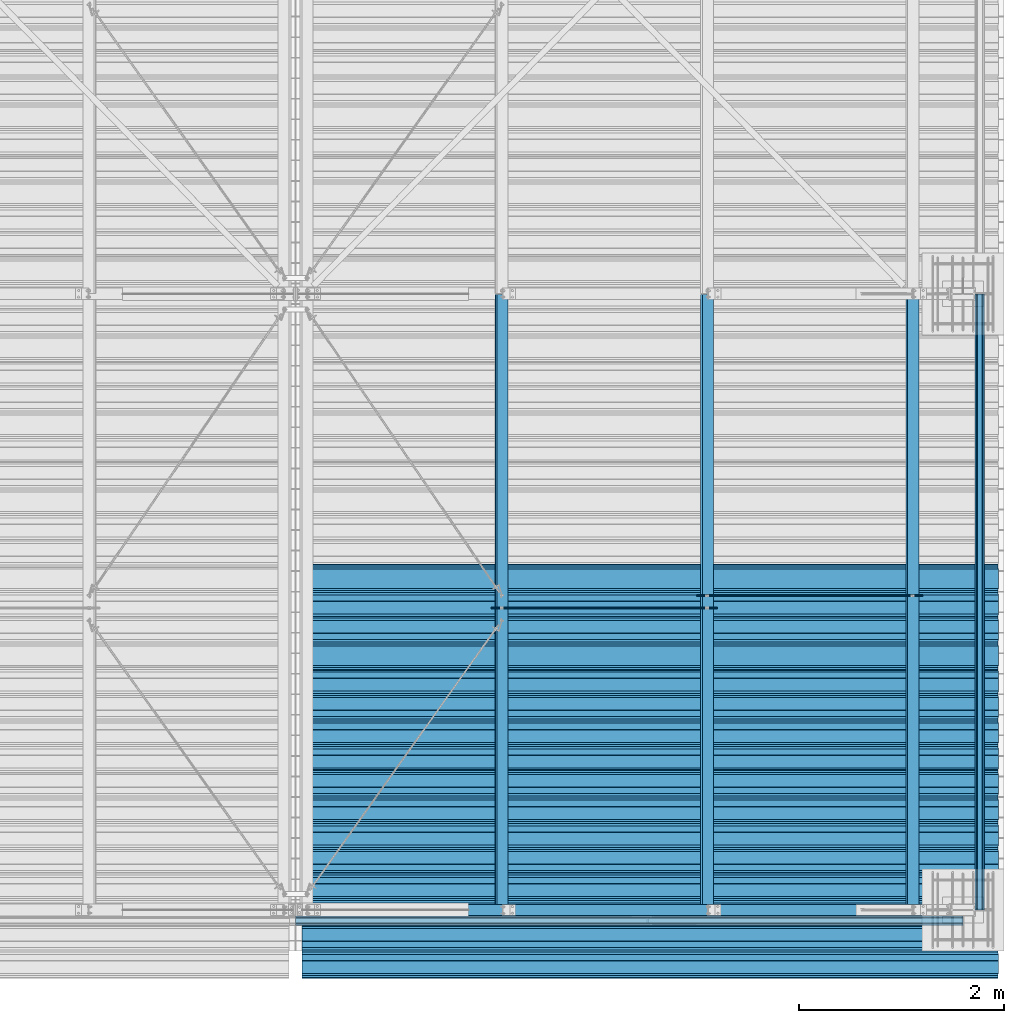
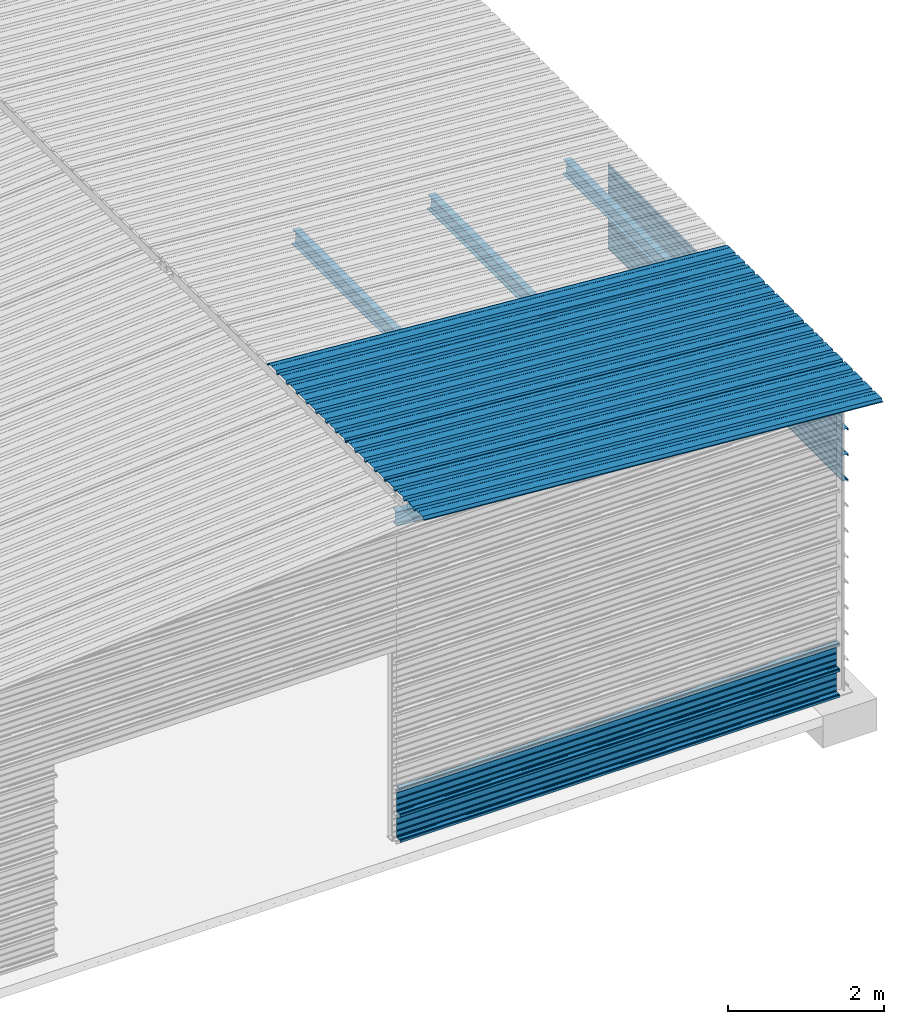
# One storey, part 8 of 70: 16 beams, 16 elements without a shape of their own.
"""IFC2X3 building model written with IfcOpenShell, lengths in millimetres."""

from ifc_helpers import new_model, si_unit, frame, origin_with_axes, origin_2d_with_axis, place, context, subcontext, project, spatial, polyline, circle, i_section, outline, extrude, clip, halfspace, material, type_object, element, aggregate, save


model = new_model("IFC2X3")

# Units and contexts
model_context = context("Model", 3, precision=1e-05, world=origin_with_axes())
body_context = subcontext(model_context, "Body", "Model", "MODEL_VIEW")
ifc_project = project(units=[si_unit("LENGTHUNIT", "METRE", prefix="MILLI"), si_unit("AREAUNIT", "SQUARE_METRE"), si_unit("VOLUMEUNIT", "CUBIC_METRE"), si_unit("MASSUNIT", "GRAM", prefix="KILO"), si_unit("TIMEUNIT", "SECOND"), si_unit("PLANEANGLEUNIT", "RADIAN"), si_unit("SOLIDANGLEUNIT", "STERADIAN"), si_unit("THERMODYNAMICTEMPERATUREUNIT", "DEGREE_CELSIUS"), si_unit("LUMINOUSINTENSITYUNIT", "LUMEN")], contexts=[model_context])

# Site, building, storey
site_placement = place(None, origin_with_axes())
site = spatial("IfcSite", under=ifc_project, at=site_placement, CompositionType="ELEMENT")
building_placement = place(site_placement, origin_with_axes())
building = spatial("IfcBuilding", under=site, at=building_placement, Name="Undefined", CompositionType="ELEMENT")
storey_placement = place(building_placement, origin_with_axes())
storey = spatial("IfcBuildingStorey", under=building, at=storey_placement, Name="Undefined", CompositionType="ELEMENT", Elevation=0.0)

# Assembly, beam
assembly_1_placement = place(storey_placement, origin_with_axes())
assembly_1 = element("IfcElementAssembly", 1, at=assembly_1_placement, inside=storey, Name="Steel Assembly", AssemblyPlace="NOTDEFINED", PredefinedType="RIGID_FRAME")
ifc_material = material(Name="STEEL/S235JR")
beam_type_1 = type_object("IfcBeamType", Name="4.40", PredefinedType="NOTDEFINED")
beam_1_placement = place(assembly_1_placement, frame((6563.60751131961, -149.999999999847, 5336.31760454349), z_axis=(-0.0766964990376782, 0.0, -0.997054485489817), x_axis=(0.997054485489817, 0.0, -0.0766964990376783)))
beam_1 = element("IfcBeam", 2, at=beam_1_placement, type_object=beam_type_1, material=ifc_material, ObjectType="4.40", context=body_context, shape_type="SweptSolid", body=[
    extrude(outline(polyline([(509.415161132813, 19.5000000011705), (490.584838867188, 19.5000000011705), (468.084838867188, -20.4999999988113), (406.585784912109, -20.4999999988113), (404.585784912109, -18.4999999988122), (345.414215087891, -18.4999999988122), (343.414215087891, -20.4999999988113), (281.915161132813, -20.4999999988113), (259.415161132813, 19.5000000011705), (240.584854125977, 19.5000000011705), (218.084854125977, -20.4999999988113), (156.585784912109, -20.4999999988113), (154.585784912109, -18.4999999988122), (95.4142150878906, -18.4999999988122), (93.4142150878906, -20.4999999988113), (31.9151515960693, -20.4999999988113), (9.41515254974365, 19.5000000011705), (-9.41515254974365, 19.5000000011705), (-31.9151515960693, -20.4999999988113), (-93.4142150878906, -20.4999999988113), (-95.4142150878906, -18.4999999988122), (-154.585784912109, -18.4999999988122), (-156.585784912109, -20.4999999988113), (-218.084854125977, -20.4999999988113), (-240.584854125977, 19.5000000011705), (-259.415161132813, 19.5000000011705), (-281.915161132813, -20.4999999988113), (-343.414215087891, -20.4999999988113), (-345.414215087891, -18.4999999988122), (-404.585784912109, -18.4999999988122), (-406.585784912109, -20.4999999988113), (-468.084838867188, -20.4999999988113), (-490.584838867188, 19.5000000011705), (-509.415161132813, 19.5000000011705), (-516.482360839844, 6.9361057293263), (-517.353942871094, 7.42636680720625), (-510.0, 20.5000000011705), (-490.0, 20.5000000011705), (-467.5, -19.4999999988122), (-407.0, -19.4999999988122), (-405.0, -17.4999999988131), (-345.0, -17.4999999988131), (-343.0, -19.4999999988122), (-282.5, -19.4999999988122), (-260.0, 20.5000000011705), (-240.0, 20.5000000011705), (-217.5, -19.4999999988122), (-157.0, -19.4999999988122), (-155.0, -17.4999999988131), (-95.0, -17.4999999988131), (-93.0, -19.4999999988122), (-32.5, -19.4999999988122), (-10.0, 20.5000000011705), (10.0, 20.5000000011705), (32.5, -19.4999999988122), (93.0, -19.4999999988122), (95.0, -17.4999999988131), (155.0, -17.4999999988131), (157.0, -19.4999999988122), (217.5, -19.4999999988122), (240.0, 20.5000000011705), (260.0, 20.5000000011705), (282.5, -19.4999999988122), (343.0, -19.4999999988122), (345.0, -17.4999999988131), (405.0, -17.4999999988131), (407.0, -19.4999999988122), (467.5, -19.4999999988122), (490.0, 20.5000000011705), (510.0, 20.5000000011705), (517.353942871094, 7.42636680720625), (516.482360839844, 6.9361057293263), (509.415161132813, 19.5000000011705)])), frame((6799.99999999733, 2.8421709430404e-14, 0.0), z_axis=(-1.0, 0.0, 0.0), x_axis=(0.0, -1.0, 0.0)), (0.0, 0.0, 1.0), 6800.0),
])
aggregate(assembly_1, [beam_1])

assembly_2_placement = place(storey_placement, origin_with_axes())
assembly_2 = element("IfcElementAssembly", 3, at=assembly_2_placement, inside=storey, Name="Steel Assembly", AssemblyPlace="NOTDEFINED", PredefinedType="RIGID_FRAME")
beam_2_placement = place(assembly_2_placement, frame((6563.60751131961, 850.000000000153, 5336.31760454352), z_axis=(-0.0766964990376782, 0.0, -0.997054485489817), x_axis=(0.997054485489817, 0.0, -0.0766964990376783)))
beam_2 = element("IfcBeam", 4, at=beam_2_placement, type_object=beam_type_1, material=ifc_material, ObjectType="4.40", context=body_context, shape_type="SweptSolid", body=[
    extrude(outline(polyline([(509.415161132813, 19.5000000011705), (490.584838867188, 19.5000000011705), (468.084838867188, -20.4999999988113), (406.585784912109, -20.4999999988113), (404.585784912109, -18.4999999988122), (345.414215087891, -18.4999999988122), (343.414215087891, -20.4999999988113), (281.915161132813, -20.4999999988113), (259.415161132813, 19.5000000011705), (240.584854125977, 19.5000000011705), (218.084854125977, -20.4999999988113), (156.585784912109, -20.4999999988113), (154.585784912109, -18.4999999988122), (95.4142150878906, -18.4999999988122), (93.4142150878906, -20.4999999988113), (31.9151515960693, -20.4999999988113), (9.41515254974365, 19.5000000011705), (-9.41515254974365, 19.5000000011705), (-31.9151515960693, -20.4999999988113), (-93.4142150878906, -20.4999999988113), (-95.4142150878906, -18.4999999988122), (-154.585784912109, -18.4999999988122), (-156.585784912109, -20.4999999988113), (-218.084854125977, -20.4999999988113), (-240.584854125977, 19.5000000011705), (-259.415161132813, 19.5000000011705), (-281.915161132813, -20.4999999988113), (-343.414215087891, -20.4999999988113), (-345.414215087891, -18.4999999988122), (-404.585784912109, -18.4999999988122), (-406.585784912109, -20.4999999988113), (-468.084838867188, -20.4999999988113), (-490.584838867188, 19.5000000011705), (-509.415161132813, 19.5000000011705), (-516.482360839844, 6.9361057293263), (-517.353942871094, 7.42636680720625), (-510.0, 20.5000000011705), (-490.0, 20.5000000011705), (-467.5, -19.4999999988122), (-407.0, -19.4999999988122), (-405.0, -17.4999999988131), (-345.0, -17.4999999988131), (-343.0, -19.4999999988122), (-282.5, -19.4999999988122), (-260.0, 20.5000000011705), (-240.0, 20.5000000011705), (-217.5, -19.4999999988122), (-157.0, -19.4999999988122), (-155.0, -17.4999999988131), (-95.0, -17.4999999988131), (-93.0, -19.4999999988122), (-32.5, -19.4999999988122), (-10.0, 20.5000000011705), (10.0, 20.5000000011705), (32.5, -19.4999999988122), (93.0, -19.4999999988122), (95.0, -17.4999999988131), (155.0, -17.4999999988131), (157.0, -19.4999999988122), (217.5, -19.4999999988122), (240.0, 20.5000000011705), (260.0, 20.5000000011705), (282.5, -19.4999999988122), (343.0, -19.4999999988122), (345.0, -17.4999999988131), (405.0, -17.4999999988131), (407.0, -19.4999999988122), (467.5, -19.4999999988122), (490.0, 20.5000000011705), (510.0, 20.5000000011705), (517.353942871094, 7.42636680720625), (516.482360839844, 6.9361057293263), (509.415161132813, 19.5000000011705)])), frame((6799.99999999733, 2.8421709430404e-14, 0.0), z_axis=(-1.0, 0.0, 0.0), x_axis=(0.0, -1.0, 0.0)), (0.0, 0.0, 1.0), 6800.0),
])
aggregate(assembly_2, [beam_2])

assembly_3_placement = place(storey_placement, origin_with_axes())
assembly_3 = element("IfcElementAssembly", 5, at=assembly_3_placement, inside=storey, Name="Steel Assembly", AssemblyPlace="NOTDEFINED", PredefinedType="RIGID_FRAME")
beam_3_placement = place(assembly_3_placement, frame((6563.60751131961, 1850.00000000015, 5336.31760454355), z_axis=(-0.0766964990376782, 0.0, -0.997054485489817), x_axis=(0.997054485489817, 0.0, -0.0766964990376783)))
beam_3 = element("IfcBeam", 6, at=beam_3_placement, type_object=beam_type_1, material=ifc_material, ObjectType="4.40", context=body_context, shape_type="SweptSolid", body=[
    extrude(outline(polyline([(509.415161132813, 19.5000000011705), (490.584838867188, 19.5000000011705), (468.084838867188, -20.4999999988113), (406.585784912109, -20.4999999988113), (404.585784912109, -18.4999999988122), (345.414215087891, -18.4999999988122), (343.414215087891, -20.4999999988113), (281.915161132813, -20.4999999988113), (259.415161132813, 19.5000000011705), (240.584854125977, 19.5000000011705), (218.084854125977, -20.4999999988113), (156.585784912109, -20.4999999988113), (154.585784912109, -18.4999999988122), (95.4142150878906, -18.4999999988122), (93.4142150878906, -20.4999999988113), (31.9151515960693, -20.4999999988113), (9.41515254974365, 19.5000000011705), (-9.41515254974365, 19.5000000011705), (-31.9151515960693, -20.4999999988113), (-93.4142150878906, -20.4999999988113), (-95.4142150878906, -18.4999999988122), (-154.585784912109, -18.4999999988122), (-156.585784912109, -20.4999999988113), (-218.084854125977, -20.4999999988113), (-240.584854125977, 19.5000000011705), (-259.415161132813, 19.5000000011705), (-281.915161132813, -20.4999999988113), (-343.414215087891, -20.4999999988113), (-345.414215087891, -18.4999999988122), (-404.585784912109, -18.4999999988122), (-406.585784912109, -20.4999999988113), (-468.084838867188, -20.4999999988113), (-490.584838867188, 19.5000000011705), (-509.415161132813, 19.5000000011705), (-516.482360839844, 6.9361057293263), (-517.353942871094, 7.42636680720625), (-510.0, 20.5000000011705), (-490.0, 20.5000000011705), (-467.5, -19.4999999988122), (-407.0, -19.4999999988122), (-405.0, -17.4999999988131), (-345.0, -17.4999999988131), (-343.0, -19.4999999988122), (-282.5, -19.4999999988122), (-260.0, 20.5000000011705), (-240.0, 20.5000000011705), (-217.5, -19.4999999988122), (-157.0, -19.4999999988122), (-155.0, -17.4999999988131), (-95.0, -17.4999999988131), (-93.0, -19.4999999988122), (-32.5, -19.4999999988122), (-10.0, 20.5000000011705), (10.0, 20.5000000011705), (32.5, -19.4999999988122), (93.0, -19.4999999988122), (95.0, -17.4999999988131), (155.0, -17.4999999988131), (157.0, -19.4999999988122), (217.5, -19.4999999988122), (240.0, 20.5000000011705), (260.0, 20.5000000011705), (282.5, -19.4999999988122), (343.0, -19.4999999988122), (345.0, -17.4999999988131), (405.0, -17.4999999988131), (407.0, -19.4999999988122), (467.5, -19.4999999988122), (490.0, 20.5000000011705), (510.0, 20.5000000011705), (517.353942871094, 7.42636680720625), (516.482360839844, 6.9361057293263), (509.415161132813, 19.5000000011705)])), frame((6799.99999999733, 2.8421709430404e-14, 0.0), z_axis=(-1.0, 0.0, 0.0), x_axis=(0.0, -1.0, 0.0)), (0.0, 0.0, 1.0), 6800.0),
])
aggregate(assembly_3, [beam_3])

assembly_4_placement = place(storey_placement, origin_with_axes())
assembly_4 = element("IfcElementAssembly", 7, at=assembly_4_placement, inside=storey, Name="Steel Assembly", AssemblyPlace="NOTDEFINED", PredefinedType="RIGID_FRAME")
beam_4_placement = place(assembly_4_placement, frame((6563.60751131961, 2850.00000000015, 5336.31760454358), z_axis=(-0.0766964990376782, 0.0, -0.997054485489817), x_axis=(0.997054485489817, 0.0, -0.0766964990376783)))
beam_4 = element("IfcBeam", 8, at=beam_4_placement, type_object=beam_type_1, material=ifc_material, ObjectType="4.40", context=body_context, shape_type="SweptSolid", body=[
    extrude(outline(polyline([(509.415161132813, 19.5000000011705), (490.584838867188, 19.5000000011705), (468.084838867188, -20.4999999988113), (406.585784912109, -20.4999999988113), (404.585784912109, -18.4999999988122), (345.414215087891, -18.4999999988122), (343.414215087891, -20.4999999988113), (281.915161132813, -20.4999999988113), (259.415161132813, 19.5000000011705), (240.584854125977, 19.5000000011705), (218.084854125977, -20.4999999988113), (156.585784912109, -20.4999999988113), (154.585784912109, -18.4999999988122), (95.4142150878906, -18.4999999988122), (93.4142150878906, -20.4999999988113), (31.9151515960693, -20.4999999988113), (9.41515254974365, 19.5000000011705), (-9.41515254974365, 19.5000000011705), (-31.9151515960693, -20.4999999988113), (-93.4142150878906, -20.4999999988113), (-95.4142150878906, -18.4999999988122), (-154.585784912109, -18.4999999988122), (-156.585784912109, -20.4999999988113), (-218.084854125977, -20.4999999988113), (-240.584854125977, 19.5000000011705), (-259.415161132813, 19.5000000011705), (-281.915161132813, -20.4999999988113), (-343.414215087891, -20.4999999988113), (-345.414215087891, -18.4999999988122), (-404.585784912109, -18.4999999988122), (-406.585784912109, -20.4999999988113), (-468.084838867188, -20.4999999988113), (-490.584838867188, 19.5000000011705), (-509.415161132813, 19.5000000011705), (-516.482360839844, 6.9361057293263), (-517.353942871094, 7.42636680720625), (-510.0, 20.5000000011705), (-490.0, 20.5000000011705), (-467.5, -19.4999999988122), (-407.0, -19.4999999988122), (-405.0, -17.4999999988131), (-345.0, -17.4999999988131), (-343.0, -19.4999999988122), (-282.5, -19.4999999988122), (-260.0, 20.5000000011705), (-240.0, 20.5000000011705), (-217.5, -19.4999999988122), (-157.0, -19.4999999988122), (-155.0, -17.4999999988131), (-95.0, -17.4999999988131), (-93.0, -19.4999999988122), (-32.5, -19.4999999988122), (-10.0, 20.5000000011705), (10.0, 20.5000000011705), (32.5, -19.4999999988122), (93.0, -19.4999999988122), (95.0, -17.4999999988131), (155.0, -17.4999999988131), (157.0, -19.4999999988122), (217.5, -19.4999999988122), (240.0, 20.5000000011705), (260.0, 20.5000000011705), (282.5, -19.4999999988122), (343.0, -19.4999999988122), (345.0, -17.4999999988131), (405.0, -17.4999999988131), (407.0, -19.4999999988122), (467.5, -19.4999999988122), (490.0, 20.5000000011705), (510.0, 20.5000000011705), (517.353942871094, 7.42636680720625), (516.482360839844, 6.9361057293263), (509.415161132813, 19.5000000011705)])), frame((6799.99999999733, 2.8421709430404e-14, 0.0), z_axis=(-1.0, 0.0, 0.0), x_axis=(0.0, -1.0, 0.0)), (0.0, 0.0, 1.0), 6800.0),
])
aggregate(assembly_4, [beam_4])

assembly_5_placement = place(storey_placement, origin_with_axes())
assembly_5 = element("IfcElementAssembly", 9, at=assembly_5_placement, inside=storey, Name="Steel Assembly", AssemblyPlace="NOTDEFINED", PredefinedType="RIGID_FRAME")
beam_type_2 = type_object("IfcBeamType", Name="400", PredefinedType="NOTDEFINED")
beam_5_placement = place(assembly_5_placement, frame((13000.0, -105.5, 618.25), z_axis=(0.0, -1.0, 0.0), x_axis=(-1.0, 0.0, 0.0)))
beam_5 = element("IfcBeam", 10, at=beam_5_placement, type_object=beam_type_2, material=ifc_material, ObjectType="400", context=body_context, shape_type="SweptSolid", body=[
    extrude(outline(polyline([(218.25, -24.994083404541), (214.25, -31.8999996185303), (214.25, -45.5), (199.75, -45.5), (194.25, -42.5), (188.75, -45.5), (124.25, -45.5), (114.25, -41.5), (104.25, -45.5), (24.25, -45.5), (14.25, -41.5), (4.25, -45.5), (-75.75, -45.5), (-85.75, -41.5), (-95.75, -45.5), (-160.25, -45.5), (-165.75, -42.5), (-171.25, -45.5), (-185.75, -45.5), (-185.75, -30.711540222168), (-181.75, -23.8111782073975), (-181.75, 23.311637878418), (-185.75, 30.2119998931885), (-185.75, 44.5), (-217.25, 44.5), (-217.25, 34.7999992370605), (-218.25, 34.7999992370605), (-218.25, 45.5), (-184.75, 45.5), (-184.75, 30.480884552002), (-180.75, 23.5805225372314), (-180.75, -24.0800628662109), (-184.75, -30.9804248809814), (-184.75, -44.5), (-171.504989624023, -44.5), (-165.75, -41.360912322998), (-159.995010375977, -44.5), (-95.9425811767578, -44.5), (-85.75, -40.422966003418), (-75.5574188232422, -44.5), (4.05741739273071, -44.5), (14.25, -40.422966003418), (24.4425830841064, -44.5), (104.057418823242, -44.5), (114.25, -40.422966003418), (124.442581176758, -44.5), (188.495010375977, -44.5), (194.25, -41.360912322998), (200.004989624023, -44.5), (213.25, -44.5), (213.25, -31.6313018798828), (217.25, -24.7253856658936), (217.25, 21.7253856658936), (213.25, 28.6313018798828), (213.25, 42.0), (187.25, 42.0), (187.25, 32.5499992370605), (186.25, 32.5499992370605), (186.25, 43.0), (214.25, 43.0), (214.25, 28.8999996185303), (218.25, 21.994083404541), (218.25, -24.994083404541)])), frame((6500.0, 0.0, 0.0), z_axis=(-1.0, 0.0, 0.0), x_axis=(0.0, -1.0, 0.0)), (0.0, 0.0, 1.0), 6500.0),
])
aggregate(assembly_5, [beam_5])

assembly_6_placement = place(storey_placement, origin_with_axes())
assembly_6 = element("IfcElementAssembly", 11, at=assembly_6_placement, inside=storey, Name="Steel Assembly", AssemblyPlace="NOTDEFINED", PredefinedType="RIGID_FRAME")
beam_6_placement = place(assembly_6_placement, frame((13000.0, -105.5, 218.25), z_axis=(0.0, -1.0, 0.0), x_axis=(-1.0, 0.0, 0.0)))
beam_6 = element("IfcBeam", 12, at=beam_6_placement, type_object=beam_type_2, material=ifc_material, ObjectType="400", context=body_context, shape_type="SweptSolid", body=[
    extrude(outline(polyline([(218.25, -24.994083404541), (214.25, -31.8999996185303), (214.25, -45.5), (199.75, -45.5), (194.25, -42.5), (188.75, -45.5), (124.25, -45.5), (114.25, -41.5), (104.25, -45.5), (24.25, -45.5), (14.25, -41.5), (4.25, -45.5), (-75.75, -45.5), (-85.75, -41.5), (-95.75, -45.5), (-160.25, -45.5), (-165.75, -42.5), (-171.25, -45.5), (-185.75, -45.5), (-185.75, -30.711540222168), (-181.75, -23.8111782073975), (-181.75, 23.311637878418), (-185.75, 30.2119998931885), (-185.75, 44.5), (-217.25, 44.5), (-217.25, 34.7999992370605), (-218.25, 34.7999992370605), (-218.25, 45.5), (-184.75, 45.5), (-184.75, 30.480884552002), (-180.75, 23.5805225372314), (-180.75, -24.0800628662109), (-184.75, -30.9804248809814), (-184.75, -44.5), (-171.504989624023, -44.5), (-165.75, -41.360912322998), (-159.995010375977, -44.5), (-95.9425811767578, -44.5), (-85.75, -40.422966003418), (-75.5574188232422, -44.5), (4.05741739273071, -44.5), (14.25, -40.422966003418), (24.4425830841064, -44.5), (104.057418823242, -44.5), (114.25, -40.422966003418), (124.442581176758, -44.5), (188.495010375977, -44.5), (194.25, -41.360912322998), (200.004989624023, -44.5), (213.25, -44.5), (213.25, -31.6313018798828), (217.25, -24.7253856658936), (217.25, 21.7253856658936), (213.25, 28.6313018798828), (213.25, 42.0), (187.25, 42.0), (187.25, 32.5499992370605), (186.25, 32.5499992370605), (186.25, 43.0), (214.25, 43.0), (214.25, 28.8999996185303), (218.25, 21.994083404541), (218.25, -24.994083404541)])), frame((6500.0, 0.0, 0.0), z_axis=(-1.0, 0.0, 0.0), x_axis=(0.0, -1.0, 0.0)), (0.0, 0.0, 1.0), 6500.0),
])
aggregate(assembly_6, [beam_6])

assembly_7_placement = place(storey_placement, origin_with_axes())
assembly_7 = element("IfcElementAssembly", 13, at=assembly_7_placement, inside=storey, Name="Steel Assembly", AssemblyPlace="NOTDEFINED", PredefinedType="RIGID_FRAME")
beam_7_placement = place(assembly_7_placement, frame((13165.4999999983, 6000.0, 4618.17396601053), z_axis=(1.0, 0.0, 0.0), x_axis=(0.0, -1.0, 0.0)))
beam_7 = element("IfcBeam", 14, at=beam_7_placement, type_object=beam_type_2, material=ifc_material, ObjectType="400", context=body_context, shape_type="Clipping", body=[
    clip(extrude(outline(polyline([(218.25, -24.994083404541), (214.25, -31.8999996185303), (214.25, -45.5), (199.75, -45.5), (194.25, -42.5), (188.75, -45.5), (124.25, -45.5), (114.25, -41.5), (104.25, -45.5), (24.25, -45.5), (14.25, -41.5), (4.25, -45.5), (-75.75, -45.5), (-85.75, -41.5), (-95.75, -45.5), (-160.25, -45.5), (-165.75, -42.5), (-171.25, -45.5), (-185.75, -45.5), (-185.75, -30.711540222168), (-181.75, -23.8111782073975), (-181.75, 23.311637878418), (-185.75, 30.2119998931885), (-185.75, 44.5), (-217.25, 44.5), (-217.25, 34.7999992370605), (-218.25, 34.7999992370605), (-218.25, 45.5), (-184.75, 45.5), (-184.75, 30.480884552002), (-180.75, 23.5805225372314), (-180.75, -24.0800628662109), (-184.75, -30.9804248809814), (-184.75, -44.5), (-171.504989624023, -44.5), (-165.75, -41.360912322998), (-159.995010375977, -44.5), (-95.9425811767578, -44.5), (-85.75, -40.422966003418), (-75.5574188232422, -44.5), (4.05741739273071, -44.5), (14.25, -40.422966003418), (24.4425830841064, -44.5), (104.057418823242, -44.5), (114.25, -40.422966003418), (124.442581176758, -44.5), (188.495010375977, -44.5), (194.25, -41.360912322998), (200.004989624023, -44.5), (213.25, -44.5), (213.25, -31.6313018798828), (217.25, -24.7253856658936), (217.25, 21.7253856658936), (213.25, 28.6313018798828), (213.25, 42.0), (187.25, 42.0), (187.25, 32.5499992370605), (186.25, 32.5499992370605), (186.25, 43.0), (214.25, 43.0), (214.25, 28.8999996185303), (218.25, 21.994083404541), (218.25, -24.994083404541)])), frame((6000.0, 0.0, 0.0), z_axis=(-1.0, 0.0, 0.0), x_axis=(0.0, -1.0, 0.0)), (0.0, 0.0, 1.0), 6000.0), halfspace(frame((6000.0, 36.6804312648892, -44.9999999999927), z_axis=(0.0, -1.0, 0.0), x_axis=(-1.0, 0.0, 0.0)), False)),
])
aggregate(assembly_7, [beam_7])

assembly_8_placement = place(storey_placement, origin_with_axes())
assembly_8 = element("IfcElementAssembly", 15, at=assembly_8_placement, inside=storey, Name="Steel Assembly", AssemblyPlace="NOTDEFINED", PredefinedType="RIGID_FRAME")
beam_8_placement = place(assembly_8_placement, frame((13165.4999999985, 6000.0, 4218.17396601053), z_axis=(1.0, 0.0, 0.0), x_axis=(0.0, -1.0, 0.0)))
beam_8 = element("IfcBeam", 16, at=beam_8_placement, type_object=beam_type_2, material=ifc_material, ObjectType="400", context=body_context, shape_type="SweptSolid", body=[
    extrude(outline(polyline([(218.25, -24.994083404541), (214.25, -31.8999996185303), (214.25, -45.5), (199.75, -45.5), (194.25, -42.5), (188.75, -45.5), (124.25, -45.5), (114.25, -41.5), (104.25, -45.5), (24.25, -45.5), (14.25, -41.5), (4.25, -45.5), (-75.75, -45.5), (-85.75, -41.5), (-95.75, -45.5), (-160.25, -45.5), (-165.75, -42.5), (-171.25, -45.5), (-185.75, -45.5), (-185.75, -30.711540222168), (-181.75, -23.8111782073975), (-181.75, 23.311637878418), (-185.75, 30.2119998931885), (-185.75, 44.5), (-217.25, 44.5), (-217.25, 34.7999992370605), (-218.25, 34.7999992370605), (-218.25, 45.5), (-184.75, 45.5), (-184.75, 30.480884552002), (-180.75, 23.5805225372314), (-180.75, -24.0800628662109), (-184.75, -30.9804248809814), (-184.75, -44.5), (-171.504989624023, -44.5), (-165.75, -41.360912322998), (-159.995010375977, -44.5), (-95.9425811767578, -44.5), (-85.75, -40.422966003418), (-75.5574188232422, -44.5), (4.05741739273071, -44.5), (14.25, -40.422966003418), (24.4425830841064, -44.5), (104.057418823242, -44.5), (114.25, -40.422966003418), (124.442581176758, -44.5), (188.495010375977, -44.5), (194.25, -41.360912322998), (200.004989624023, -44.5), (213.25, -44.5), (213.25, -31.6313018798828), (217.25, -24.7253856658936), (217.25, 21.7253856658936), (213.25, 28.6313018798828), (213.25, 42.0), (187.25, 42.0), (187.25, 32.5499992370605), (186.25, 32.5499992370605), (186.25, 43.0), (214.25, 43.0), (214.25, 28.8999996185303), (218.25, 21.994083404541), (218.25, -24.994083404541)])), frame((6000.0, 0.0, 0.0), z_axis=(-1.0, 0.0, 0.0), x_axis=(0.0, -1.0, 0.0)), (0.0, 0.0, 1.0), 6000.0),
])
aggregate(assembly_8, [beam_8])

assembly_9_placement = place(storey_placement, origin_with_axes())
assembly_9 = element("IfcElementAssembly", 17, at=assembly_9_placement, inside=storey, Name="Steel Assembly", AssemblyPlace="NOTDEFINED", PredefinedType="RIGID_FRAME")
beam_9_placement = place(assembly_9_placement, frame((13165.4999999986, 6000.0, 3818.17396601053), z_axis=(1.0, 0.0, 0.0), x_axis=(0.0, -1.0, 0.0)))
beam_9 = element("IfcBeam", 18, at=beam_9_placement, type_object=beam_type_2, material=ifc_material, ObjectType="400", context=body_context, shape_type="SweptSolid", body=[
    extrude(outline(polyline([(218.25, -24.994083404541), (214.25, -31.8999996185303), (214.25, -45.5), (199.75, -45.5), (194.25, -42.5), (188.75, -45.5), (124.25, -45.5), (114.25, -41.5), (104.25, -45.5), (24.25, -45.5), (14.25, -41.5), (4.25, -45.5), (-75.75, -45.5), (-85.75, -41.5), (-95.75, -45.5), (-160.25, -45.5), (-165.75, -42.5), (-171.25, -45.5), (-185.75, -45.5), (-185.75, -30.711540222168), (-181.75, -23.8111782073975), (-181.75, 23.311637878418), (-185.75, 30.2119998931885), (-185.75, 44.5), (-217.25, 44.5), (-217.25, 34.7999992370605), (-218.25, 34.7999992370605), (-218.25, 45.5), (-184.75, 45.5), (-184.75, 30.480884552002), (-180.75, 23.5805225372314), (-180.75, -24.0800628662109), (-184.75, -30.9804248809814), (-184.75, -44.5), (-171.504989624023, -44.5), (-165.75, -41.360912322998), (-159.995010375977, -44.5), (-95.9425811767578, -44.5), (-85.75, -40.422966003418), (-75.5574188232422, -44.5), (4.05741739273071, -44.5), (14.25, -40.422966003418), (24.4425830841064, -44.5), (104.057418823242, -44.5), (114.25, -40.422966003418), (124.442581176758, -44.5), (188.495010375977, -44.5), (194.25, -41.360912322998), (200.004989624023, -44.5), (213.25, -44.5), (213.25, -31.6313018798828), (217.25, -24.7253856658936), (217.25, 21.7253856658936), (213.25, 28.6313018798828), (213.25, 42.0), (187.25, 42.0), (187.25, 32.5499992370605), (186.25, 32.5499992370605), (186.25, 43.0), (214.25, 43.0), (214.25, 28.8999996185303), (218.25, 21.994083404541), (218.25, -24.994083404541)])), frame((6000.0, 0.0, 0.0), z_axis=(-1.0, 0.0, 0.0), x_axis=(0.0, -1.0, 0.0)), (0.0, 0.0, 1.0), 6000.0),
])
aggregate(assembly_9, [beam_9])

assembly_10_placement = place(storey_placement, origin_with_axes())
assembly_10 = element("IfcElementAssembly", 19, at=assembly_10_placement, inside=storey, Name="Steel Assembly", AssemblyPlace="NOTDEFINED", PredefinedType="RIGID_FRAME")
beam_10_placement = place(assembly_10_placement, frame((13165.4999999988, 6000.0, 3418.17396601053), z_axis=(1.0, 0.0, 0.0), x_axis=(0.0, -1.0, 0.0)))
beam_10 = element("IfcBeam", 20, at=beam_10_placement, type_object=beam_type_2, material=ifc_material, ObjectType="400", context=body_context, shape_type="SweptSolid", body=[
    extrude(outline(polyline([(218.25, -24.994083404541), (214.25, -31.8999996185303), (214.25, -45.5), (199.75, -45.5), (194.25, -42.5), (188.75, -45.5), (124.25, -45.5), (114.25, -41.5), (104.25, -45.5), (24.25, -45.5), (14.25, -41.5), (4.25, -45.5), (-75.75, -45.5), (-85.75, -41.5), (-95.75, -45.5), (-160.25, -45.5), (-165.75, -42.5), (-171.25, -45.5), (-185.75, -45.5), (-185.75, -30.711540222168), (-181.75, -23.8111782073975), (-181.75, 23.311637878418), (-185.75, 30.2119998931885), (-185.75, 44.5), (-217.25, 44.5), (-217.25, 34.7999992370605), (-218.25, 34.7999992370605), (-218.25, 45.5), (-184.75, 45.5), (-184.75, 30.480884552002), (-180.75, 23.5805225372314), (-180.75, -24.0800628662109), (-184.75, -30.9804248809814), (-184.75, -44.5), (-171.504989624023, -44.5), (-165.75, -41.360912322998), (-159.995010375977, -44.5), (-95.9425811767578, -44.5), (-85.75, -40.422966003418), (-75.5574188232422, -44.5), (4.05741739273071, -44.5), (14.25, -40.422966003418), (24.4425830841064, -44.5), (104.057418823242, -44.5), (114.25, -40.422966003418), (124.442581176758, -44.5), (188.495010375977, -44.5), (194.25, -41.360912322998), (200.004989624023, -44.5), (213.25, -44.5), (213.25, -31.6313018798828), (217.25, -24.7253856658936), (217.25, 21.7253856658936), (213.25, 28.6313018798828), (213.25, 42.0), (187.25, 42.0), (187.25, 32.5499992370605), (186.25, 32.5499992370605), (186.25, 43.0), (214.25, 43.0), (214.25, 28.8999996185303), (218.25, 21.994083404541), (218.25, -24.994083404541)])), frame((6000.0, 0.0, 0.0), z_axis=(-1.0, 0.0, 0.0), x_axis=(0.0, -1.0, 0.0)), (0.0, 0.0, 1.0), 6000.0),
])
aggregate(assembly_10, [beam_10])

assembly_11_placement = place(storey_placement, origin_with_axes())
assembly_11 = element("IfcElementAssembly", 21, at=assembly_11_placement, inside=storey, Name="Steel Assembly", AssemblyPlace="NOTDEFINED", PredefinedType="RIGID_FRAME")
beam_type_3 = type_object("IfcBeamType", Name="D14", PredefinedType="NOTDEFINED")
beam_11_placement = place(assembly_11_placement, frame((10408.7311663468, 3060.00000000009, 4909.65333500212), z_axis=(-0.0766964990376782, 0.0, -0.997054485489817), x_axis=(0.997054485489817, 0.0, -0.0766964990376783)))
beam_11 = element("IfcBeam", 22, at=beam_11_placement, type_object=beam_type_3, material=ifc_material, Name="THREAD60MM", ObjectType="D14", context=body_context, shape_type="SweptSolid", body=[
    extrude(circle(Radius=7.0, at=origin_2d_with_axis()), frame((2205.90843239298, 9.09494701772928e-13, -9.40107830921147e-13), z_axis=(-1.0, 0.0, 0.0), x_axis=(0.0, -1.0, 0.0)), (0.0, 0.0, 1.0), 2205.91),
])
aggregate(assembly_11, [beam_11])

assembly_12_placement = place(storey_placement, origin_with_axes())
assembly_12 = element("IfcElementAssembly", 23, at=assembly_12_placement, inside=storey, Name="Steel Assembly", AssemblyPlace="NOTDEFINED", PredefinedType="RIGID_FRAME")
beam_12_placement = place(assembly_12_placement, frame((8408.73116634676, 2940.00000000009, 5063.49948915789), z_axis=(-0.0766964990376782, 0.0, -0.997054485489817), x_axis=(0.997054485489817, 0.0, -0.0766964990376783)))
beam_12 = element("IfcBeam", 24, at=beam_12_placement, type_object=beam_type_3, material=ifc_material, Name="THREAD60MM", ObjectType="D14", context=body_context, shape_type="SweptSolid", body=[
    extrude(circle(Radius=7.0, at=origin_2d_with_axis()), frame((2205.90843239298, 9.09494701772928e-13, -9.40107830921147e-13), z_axis=(-1.0, 0.0, 0.0), x_axis=(0.0, -1.0, 0.0)), (0.0, 0.0, 1.0), 2205.91),
])
aggregate(assembly_12, [beam_12])

assembly_13_placement = place(storey_placement, origin_with_axes())
assembly_13 = element("IfcElementAssembly", 25, at=assembly_13_placement, inside=storey, Name="Steel Assembly", AssemblyPlace="NOTDEFINED", PredefinedType="RIGID_FRAME")
beam_type_4 = type_object("IfcBeamType", Name="IPE220", PredefinedType="NOTDEFINED")
beam_13_placement = place(assembly_13_placement, frame((12508.4366148951, -149.999999999909, 4748.13753095371), z_axis=(0.0766964990376782, 0.0, 0.997054485489817), x_axis=(0.0, 1.0, 0.0)))
beam_13 = element("IfcBeam", 26, at=beam_13_placement, type_object=beam_type_4, material=ifc_material, ObjectType="IPE220", context=body_context, shape_type="Clipping", body=[
    clip(extrude(i_section(OverallWidth=110.0, OverallDepth=220.0, WebThickness=5.900000095, FlangeThickness=9.199999809, FilletRadius=12.0, at=origin_2d_with_axis()), frame((6144.99999999991, 0.0, 0.0), z_axis=(-1.0, 0.0, 0.0), x_axis=(0.0, -1.0, 0.0)), (0.0, 0.0, 1.0), 6145.0), halfspace(frame((6144.99999999991, 0.0, 0.0), z_axis=(1.0, 0.0, 0.0), x_axis=(0.0, -1.0, 0.0)), False)),
])
aggregate(assembly_13, [beam_13])

assembly_14_placement = place(storey_placement, origin_with_axes())
assembly_14 = element("IfcElementAssembly", 27, at=assembly_14_placement, inside=storey, Name="Steel Assembly", AssemblyPlace="NOTDEFINED", PredefinedType="RIGID_FRAME")
beam_14_placement = place(assembly_14_placement, frame((10508.4366148951, -149.999999999909, 4901.98368510902), z_axis=(0.0766964990376782, 0.0, 0.997054485489817), x_axis=(0.0, 1.0, 0.0)))
beam_14 = element("IfcBeam", 28, at=beam_14_placement, type_object=beam_type_4, material=ifc_material, ObjectType="IPE220", context=body_context, shape_type="Clipping", body=[
    clip(extrude(i_section(OverallWidth=110.0, OverallDepth=220.0, WebThickness=5.900000095, FlangeThickness=9.199999809, FilletRadius=12.0, at=origin_2d_with_axis()), frame((6144.99999999991, 0.0, 0.0), z_axis=(-1.0, 0.0, 0.0), x_axis=(0.0, -1.0, 0.0)), (0.0, 0.0, 1.0), 6145.0), halfspace(frame((6144.99999999991, 0.0, 0.0), z_axis=(1.0, 0.0, 0.0), x_axis=(0.0, -1.0, 0.0)), False)),
])
aggregate(assembly_14, [beam_14])

assembly_15_placement = place(storey_placement, origin_with_axes())
assembly_15 = element("IfcElementAssembly", 29, at=assembly_15_placement, inside=storey, Name="Steel Assembly", AssemblyPlace="NOTDEFINED", PredefinedType="RIGID_FRAME")
beam_15_placement = place(assembly_15_placement, frame((8508.43661489509, -149.999999999909, 5055.82983926478), z_axis=(0.0766964990376782, 0.0, 0.997054485489817), x_axis=(0.0, 1.0, 0.0)))
beam_15 = element("IfcBeam", 30, at=beam_15_placement, type_object=beam_type_4, material=ifc_material, ObjectType="IPE220", context=body_context, shape_type="Clipping", body=[
    clip(extrude(i_section(OverallWidth=110.0, OverallDepth=220.0, WebThickness=5.900000095, FlangeThickness=9.199999809, FilletRadius=12.0, at=origin_2d_with_axis()), frame((6144.99999999991, 0.0, 0.0), z_axis=(-1.0, 0.0, 0.0), x_axis=(0.0, -1.0, 0.0)), (0.0, 0.0, 1.0), 6145.0), halfspace(frame((6144.99999999991, 0.0, 0.0), z_axis=(1.0, 0.0, 0.0), x_axis=(0.0, -1.0, 0.0)), False)),
])
aggregate(assembly_15, [beam_15])

assembly_16_placement = place(storey_placement, origin_with_axes())
assembly_16 = element("IfcElementAssembly", 31, at=assembly_16_placement, inside=storey, Name="Steel Assembly", AssemblyPlace="NOTDEFINED", PredefinedType="RIGID_FRAME")
beam_16_placement = place(assembly_16_placement, frame((6491.56338512267, 0.0, 4990.32400659478), z_axis=(0.0766964990376782, 0.0, 0.997054485489817), x_axis=(0.997054485489817, 0.0, -0.0766964990376783)))
beam_16 = element("IfcBeam", 32, at=beam_16_placement, type_object=beam_type_4, material=ifc_material, Name="POUTRE", ObjectType="IPE220", context=body_context, shape_type="Clipping", body=[
    clip(clip(extrude(i_section(OverallWidth=110.0, OverallDepth=220.0, WebThickness=5.900000095, FlangeThickness=9.199999809, FilletRadius=12.0, at=origin_2d_with_axis()), frame((6409.35743228136, 3.63797880709171e-12, 8.89477024296393e-14), z_axis=(-1.0, 0.0, 0.0), x_axis=(0.0, -1.0, 0.0)), (0.0, 0.0, 1.0), 6402.94), halfspace(frame((6400.72666295692, 3.63797880709171e-12, -109.999999009079), z_axis=(-0.997054485489818, 0.0, -0.0766964990376602), x_axis=(-0.0766964990376602, 0.0, 0.997054485489818)), True)), halfspace(frame((14.9558139963001, 3.63797880709171e-12, 111.150447485664), z_axis=(-0.997054485489818, 0.0, -0.0766964990376602), x_axis=(0.0, -1.0, 0.0)), False)),
])
aggregate(assembly_16, [beam_16])

save(model, "model.ifc")
